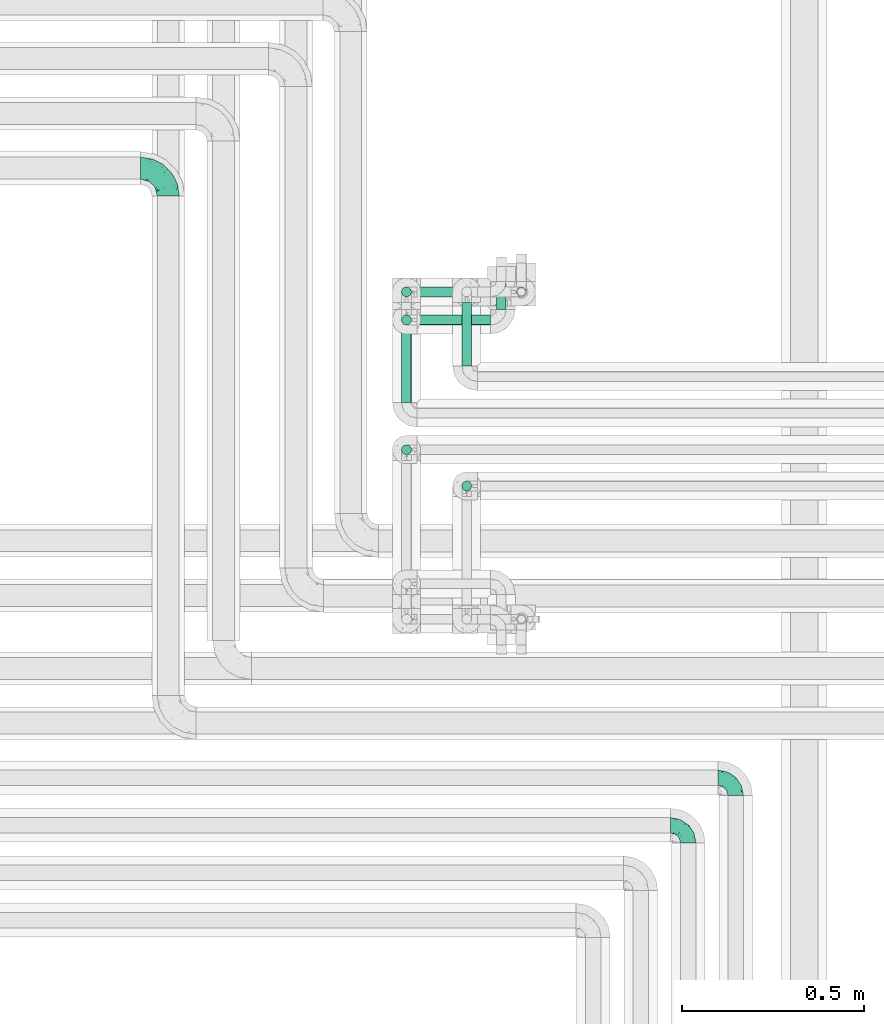
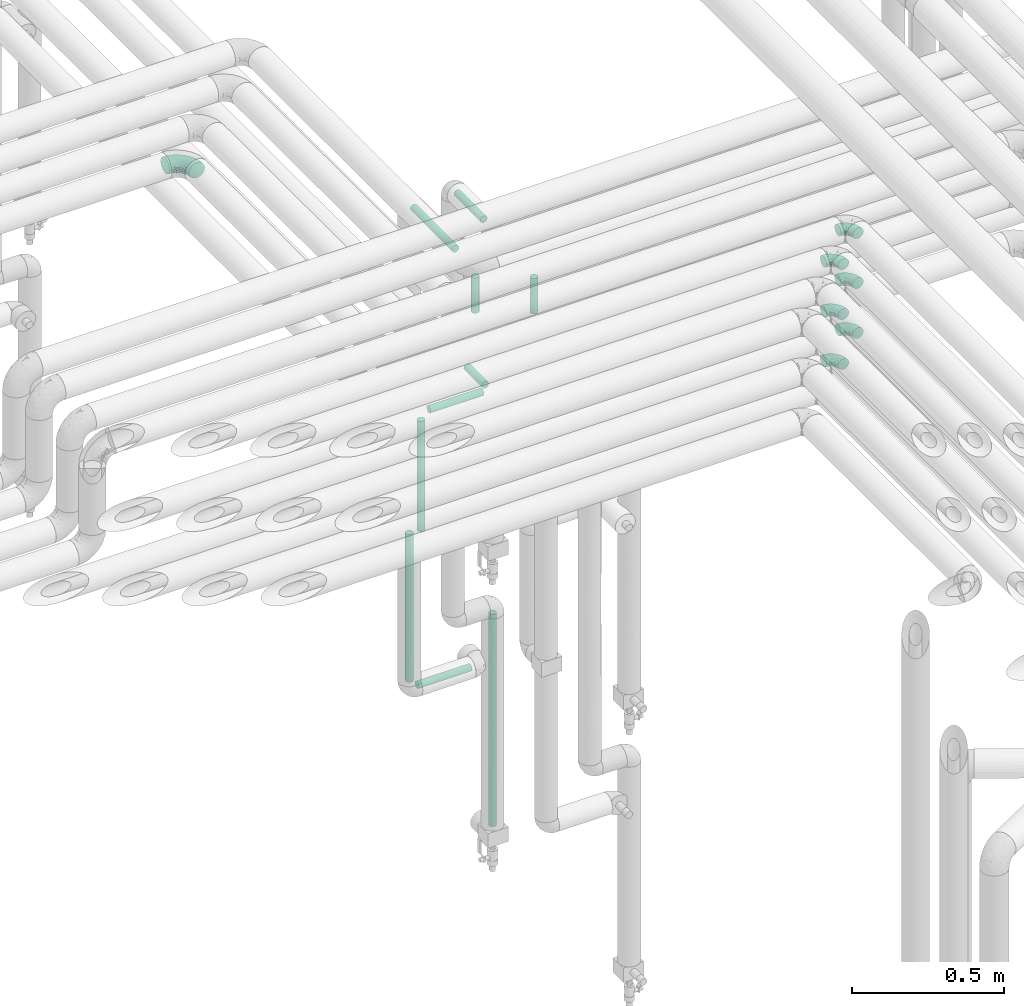
# One storey, part 636 of 827: 10 flow segments, 7 flow fittings.
"""IFC2X3 building model written with IfcOpenShell, lengths in millimetres."""

from ifc_helpers import new_model, entity, si_unit, converted_unit, derived_unit, direction, frame, origin, origin_2d_with_axis, place, context, subcontext, project, spatial, circle, extrude, faceted_brep, source, transform, mapped, material, type_object, type_shapes, element, save


model = new_model("IFC2X3")

# Units and contexts
model_context = context("Model", 3, precision=0.01, world=origin(), true_north=direction((6.12303176911189e-17, 1.0)))
body_context = subcontext(model_context, "Body", "Model", "MODEL_VIEW")
ifc_project = project(units=[si_unit("LENGTHUNIT", "METRE", prefix="MILLI"), si_unit("AREAUNIT", "SQUARE_METRE"), si_unit("VOLUMEUNIT", "CUBIC_METRE"), converted_unit("PLANEANGLEUNIT", "DEGREE", entity("IfcRatioMeasure", 0.0174532925199433), si_unit("PLANEANGLEUNIT", "RADIAN"), dimensions=[0, 0, 0, 0, 0, 0, 0]), si_unit("MASSUNIT", "GRAM", prefix="KILO"), derived_unit("MASSDENSITYUNIT", [(si_unit("MASSUNIT", "GRAM", prefix="KILO"), 1), (si_unit("LENGTHUNIT", "METRE"), -3)]), derived_unit("MOMENTOFINERTIAUNIT", [(si_unit("LENGTHUNIT", "METRE"), 4)]), si_unit("TIMEUNIT", "SECOND"), si_unit("FREQUENCYUNIT", "HERTZ"), si_unit("THERMODYNAMICTEMPERATUREUNIT", "DEGREE_CELSIUS"), derived_unit("THERMALTRANSMITTANCEUNIT", [(si_unit("MASSUNIT", "GRAM", prefix="KILO"), 1), (si_unit("THERMODYNAMICTEMPERATUREUNIT", "KELVIN"), -1), (si_unit("TIMEUNIT", "SECOND"), -3)]), derived_unit("VOLUMETRICFLOWRATEUNIT", [(si_unit("LENGTHUNIT", "METRE"), 3), (si_unit("TIMEUNIT", "SECOND"), -1)]), derived_unit("MASSFLOWRATEUNIT", [(si_unit("MASSUNIT", "GRAM", prefix="KILO"), 1), (si_unit("TIMEUNIT", "SECOND"), -1)]), derived_unit("ROTATIONALFREQUENCYUNIT", [(si_unit("TIMEUNIT", "SECOND"), -1)]), si_unit("ELECTRICCURRENTUNIT", "AMPERE"), si_unit("ELECTRICVOLTAGEUNIT", "VOLT"), si_unit("POWERUNIT", "WATT"), si_unit("FORCEUNIT", "NEWTON", prefix="KILO"), si_unit("ILLUMINANCEUNIT", "LUX"), si_unit("LUMINOUSFLUXUNIT", "LUMEN"), si_unit("LUMINOUSINTENSITYUNIT", "CANDELA"), derived_unit("USERDEFINED", [(si_unit("MASSUNIT", "GRAM", prefix="KILO"), -1), (si_unit("LENGTHUNIT", "METRE"), -2), (si_unit("TIMEUNIT", "SECOND"), 3), (si_unit("LUMINOUSFLUXUNIT", "LUMEN"), 1)]), derived_unit("LINEARVELOCITYUNIT", [(si_unit("LENGTHUNIT", "METRE"), 1), (si_unit("TIMEUNIT", "SECOND"), -1)]), si_unit("PRESSUREUNIT", "PASCAL"), derived_unit("USERDEFINED", [(si_unit("LENGTHUNIT", "METRE"), -2), (si_unit("MASSUNIT", "GRAM", prefix="KILO"), 1), (si_unit("TIMEUNIT", "SECOND"), -2)]), derived_unit("LINEARFORCEUNIT", [(si_unit("MASSUNIT", "GRAM", prefix="KILO"), 1), (si_unit("LENGTHUNIT", "METRE"), 1), (si_unit("TIMEUNIT", "SECOND"), -2), (si_unit("LENGTHUNIT", "METRE"), -1)]), derived_unit("PLANARFORCEUNIT", [(si_unit("MASSUNIT", "GRAM", prefix="KILO"), 1), (si_unit("LENGTHUNIT", "METRE"), 1), (si_unit("TIMEUNIT", "SECOND"), -2), (si_unit("LENGTHUNIT", "METRE"), -2)])], contexts=[model_context])

# Site, building, storey
site_placement = place(None, origin())
site = spatial("IfcSite", under=ifc_project, at=site_placement, CompositionType="ELEMENT")
building_placement = place(site_placement, origin())
building = spatial("IfcBuilding", under=site, at=building_placement, CompositionType="ELEMENT")
storey_placement = place(building_placement, frame((0.0, 0.0, 28200.0)))
storey = spatial("IfcBuildingStorey", under=building, at=storey_placement, Name="08", CompositionType="ELEMENT", Elevation=28200.0)

# Flow segments
pipe_segment_type = type_object("IfcPipeSegmentType", PredefinedType="NOTDEFINED")
flow_segment_1_placement = place(storey_placement, frame((34812.85, 15519.1, 2985.0)))
element("IfcFlowSegment", 1, at=flow_segment_1_placement, inside=storey, type_object=pipe_segment_type, context=body_context, shape_type="SweptSolid", body=[
    extrude(circle(Radius=13.4, at=origin_2d_with_axis()), frame((15.0, 0.0, 15.0), z_axis=(0.0, 1.0, 0.0), x_axis=(1.0, 0.0, 0.0)), (0.0, 0.0, 1.0), 273.847303750792),
])
flow_segment_2_placement = place(storey_placement, frame((34977.89, 15619.14, 2985.0)))
element("IfcFlowSegment", 2, at=flow_segment_2_placement, inside=storey, type_object=pipe_segment_type, context=body_context, shape_type="SweptSolid", body=[
    extrude(circle(Radius=13.4, at=origin_2d_with_axis()), frame((15.0, 0.0, 15.0), z_axis=(0.0, 1.0, 0.0), x_axis=(1.0, 0.0, 0.0)), (0.0, 0.0, 1.0), 173.806350271803),
])
flow_segment_3_placement = place(storey_placement, frame((35127.89, 15807.05, 401.0)))
element("IfcFlowSegment", 3, at=flow_segment_3_placement, inside=storey, type_object=pipe_segment_type, context=body_context, shape_type="SweptSolid", body=[
    extrude(circle(Radius=13.4, at=origin_2d_with_axis()), frame((15.0, 15.0, 0.0)), (0.0, 0.0, 1.0), 849.899999999534),
])
flow_segment_4_placement = place(storey_placement, frame((34812.85, 15807.05, 1089.1)))
element("IfcFlowSegment", 4, at=flow_segment_4_placement, inside=storey, type_object=pipe_segment_type, context=body_context, shape_type="SweptSolid", body=[
    extrude(circle(Radius=13.4, at=origin_2d_with_axis()), frame((15.0, 15.0, 0.0)), (0.0, 0.0, 1.0), 591.900000000008),
])
flow_segment_5_placement = place(storey_placement, frame((34856.95, 15807.05, 1045.0)))
element("IfcFlowSegment", 5, at=flow_segment_5_placement, inside=storey, type_object=pipe_segment_type, context=body_context, shape_type="SweptSolid", body=[
    extrude(circle(Radius=13.4, at=origin_2d_with_axis()), frame((0.0, 15.0, 15.0), z_axis=(1.0, 0.0, 0.0), x_axis=(0.0, -1.0, 0.0)), (0.0, 0.0, 1.0), 201.799999999997),
])
flow_segment_6_placement = place(storey_placement, frame((34856.95, 15730.06, 2195.0)))
element("IfcFlowSegment", 6, at=flow_segment_6_placement, inside=storey, type_object=pipe_segment_type, context=body_context, shape_type="SweptSolid", body=[
    extrude(circle(Radius=13.4, at=origin_2d_with_axis()), frame((0.0, 15.0, 15.0), z_axis=(1.0, 0.0, 0.0), x_axis=(0.0, 1.0, 0.0)), (0.0, 0.0, 1.0), 201.799999999997),
])
flow_segment_7_placement = place(storey_placement, frame((35072.85, 15774.15, 2195.0)))
element("IfcFlowSegment", 7, at=flow_segment_7_placement, inside=storey, type_object=pipe_segment_type, context=body_context, shape_type="SweptSolid", body=[
    extrude(circle(Radius=13.4, at=origin_2d_with_axis()), frame((15.0, 0.0, 15.0), z_axis=(0.0, 1.0, 0.0), x_axis=(-1.0, 0.0, 0.0)), (0.0, 0.0, 1.0), 117.895089895177),
])
flow_segment_8_placement = place(storey_placement, frame((34812.85, 15730.06, 1739.1)))
element("IfcFlowSegment", 8, at=flow_segment_8_placement, inside=storey, type_object=pipe_segment_type, context=body_context, shape_type="SweptSolid", body=[
    extrude(circle(Radius=13.4, at=origin_2d_with_axis()), frame((15.0, 15.0, 0.0)), (0.0, 0.0, 1.0), 441.800000000021),
])
flow_segment_9_placement = place(storey_placement, frame((34977.89, 15275.0, 2829.1)))
element("IfcFlowSegment", 9, at=flow_segment_9_placement, inside=storey, type_object=pipe_segment_type, context=body_context, shape_type="SweptSolid", body=[
    extrude(circle(Radius=13.4, at=origin_2d_with_axis()), frame((15.0, 15.0, 0.0), z_axis=(0.0, 0.0, 1.0), x_axis=(-1.0, 0.0, 0.0)), (0.0, 0.0, 1.0), 141.800000000046),
])
flow_segment_10_placement = place(storey_placement, frame((34812.85, 15374.6, 2829.1)))
element("IfcFlowSegment", 10, at=flow_segment_10_placement, inside=storey, type_object=pipe_segment_type, context=body_context, shape_type="SweptSolid", body=[
    extrude(circle(Radius=13.4, at=origin_2d_with_axis()), frame((15.0, 15.0, 0.0), z_axis=(0.0, 0.0, 1.0), x_axis=(-1.0, 0.0, 0.0)), (0.0, 0.0, 1.0), 141.800000000024),
])

# Flow fittings
ifc_material = material()
pipe_fitting_type_1 = type_object("IfcPipeFittingType", Name="ADSK_1", PredefinedType="NOTDEFINED", material=ifc_material)
shared_shape_1 = source(origin(), body_context, "Body", "Brep", [
    faceted_brep([(-48.0, 10.6, -18.36), (-48.0, 5.49, -20.48), (-48.0, 0.0, -21.2), (-48.0, -5.49, -20.48), (-48.0, -10.6, -18.36), (-48.0, -14.99, -14.99), (-48.0, -18.36, -10.6), (-48.0, -20.48, -5.49), (-48.0, -21.2, 0.0), (-48.0, -20.48, 5.49), (-48.0, -18.36, 10.6), (-48.0, -14.99, 14.99), (-48.0, -10.6, 18.36), (-48.0, -5.49, 20.48), (-48.0, 0.0, 21.2), (-48.0, 5.49, 20.48), (-48.0, 10.6, 18.36), (-48.0, 14.99, 14.99), (-48.0, 18.36, 10.6), (-48.0, 20.48, 5.49), (-48.0, 21.2, 0.0), (-48.0, 20.48, -5.49), (-48.0, 18.36, -10.6), (-48.0, 14.99, -14.99), (0.0, 48.0, -21.2), (-5.49, 48.0, -20.48), (-10.6, 48.0, -18.36), (-14.99, 48.0, -14.99), (-18.36, 48.0, -10.6), (-20.48, 48.0, -5.49), (-21.2, 48.0, 0.0), (-20.48, 48.0, 5.49), (-18.36, 48.0, 10.6), (-14.99, 48.0, 14.99), (-10.6, 48.0, 18.36), (-5.49, 48.0, 20.48), (0.0, 48.0, 21.2), (5.49, 48.0, 20.48), (10.6, 48.0, 18.36), (14.99, 48.0, 14.99), (18.36, 48.0, 10.6), (20.48, 48.0, 5.49), (21.2, 48.0, 0.0), (20.48, 48.0, -5.49), (18.36, 48.0, -10.6), (14.99, 48.0, -14.99), (10.6, 48.0, -18.36), (5.49, 48.0, -20.48), (-35.25, -16.22, 12.01), (-34.76, -18.57, 0.0), (-20.87, -12.37, 10.9), (-31.49, -11.78, 15.9), (-37.0, -2.58, 20.86), (-33.89, 3.62, 21.15), (-31.81, -18.14, 6.76), (-5.78, 5.78, 17.67), (-19.42, -4.1, 17.86), (-9.6, -3.39, 13.73), (-35.44, -7.73, 19.13), (11.78, 31.49, 15.9), (-5.93, -5.46, 6.95), (-18.45, -13.78, 5.46), (-10.29, -8.43, 0.0), (-24.6, 0.55, 20.62), (-37.28, 17.94, 13.81), (-33.38, 22.85, 9.59), (-41.46, 20.06, 8.75), (-29.51, 20.45, 15.16), (-15.04, 10.79, 21.13), (-7.08, 16.98, 20.93), (-8.39, 23.51, 21.15), (-40.86, 13.03, 17.26), (-8.05, 41.26, 19.83), (-3.21, 35.97, 21.14), (8.53, 19.66, 14.74), (4.1, 19.42, 17.86), (-37.72, 22.66, 4.78), (-37.07, 8.58, 19.98), (-13.0, 5.43, 19.97), (-3.78, 13.93, 19.7), (3.02, 8.69, 13.43), (-2.27, -0.05, 10.65), (6.22, 6.99, 7.09), (-22.25, 34.6, 9.45), (18.14, 31.81, 6.76), (16.22, 35.25, 12.01), (12.37, 20.87, 10.9), (7.73, 35.44, 19.13), (-21.52, -15.93, 0.0), (2.58, 37.0, 20.86), (18.57, 34.76, 0.0), (13.78, 18.45, 5.46), (15.93, 21.52, 0.0), (-20.03, -8.54, 14.9), (-28.6, 28.6, 5.16), (-24.79, 34.6, 0.0), (-34.6, 24.79, 0.0), (-22.81, 37.41, 4.68), (-23.36, 26.33, 14.79), (-13.68, 37.05, 17.49), (-17.72, 38.12, 13.73), (-26.25, 27.3, 11.24), (-9.71, 32.34, 20.14), (-17.26, 25.6, 18.71), (-26.33, 9.99, 20.77), (-24.06, 6.05, 21.2), (-25.02, 15.46, 19.56), (-24.3, 20.72, 17.57), (-31.95, 15.23, 17.8), (-13.53, 24.7, 20.21), (-17.6, 17.6, 20.6), (-0.55, 24.6, 20.62), (-11.41, -7.48, 10.43), (0.93, -0.93, 0.0), (8.43, 10.29, 0.0), (-11.41, -7.48, -10.43), (-20.1, -8.84, -14.66), (-9.6, -3.39, -13.73), (7.73, 35.44, -19.13), (4.1, 19.42, -17.86), (-0.55, 24.6, -20.62), (-38.12, 17.72, -13.73), (-37.05, 13.68, -17.49), (-32.34, 9.71, -20.14), (-41.26, 8.05, -19.83), (-37.41, 22.81, -4.68), (-23.51, 8.39, -21.15), (-35.97, 3.21, -21.14), (-28.6, 28.6, -5.16), (-31.81, -18.14, -6.76), (-18.45, -13.78, -5.46), (-25.6, 17.26, -18.71), (-19.42, -4.1, -17.86), (-17.94, 37.28, -13.81), (-22.85, 33.38, -9.59), (-20.06, 41.46, -8.75), (-31.49, -11.78, -15.9), (-35.25, -16.22, -12.01), (8.53, 19.66, -14.74), (11.78, 31.49, -15.9), (-9.99, 26.33, -20.77), (-6.05, 24.06, -21.2), (-10.79, 15.04, -21.13), (-37.0, -2.58, -20.86), (-16.98, 7.08, -20.93), (-5.43, 13.0, -19.97), (-13.93, 3.78, -19.7), (-20.87, -12.37, -10.9), (-26.33, 23.36, -14.79), (-22.66, 37.72, -4.78), (13.78, 18.45, -5.46), (18.14, 31.81, -6.76), (-15.46, 25.02, -19.56), (-20.72, 24.3, -17.57), (16.22, 35.25, -12.01), (-13.03, 40.86, -17.26), (-8.58, 37.07, -19.98), (2.58, 37.0, -20.86), (-3.62, 33.89, -21.15), (-34.6, 22.25, -9.45), (6.22, 6.99, -7.09), (-20.45, 29.51, -15.16), (-35.44, -7.73, -19.13), (12.37, 20.87, -10.9), (-27.3, 26.25, -11.24), (-15.23, 31.95, -17.8), (-24.7, 13.53, -20.21), (-24.6, 0.55, -20.62), (-5.78, 5.78, -17.67), (-17.6, 17.6, -20.6), (3.02, 8.69, -13.43), (-5.93, -5.46, -6.95), (-2.27, -0.05, -10.65)], [[[0, 1, 2, 3, 4, 5, 6, 7, 8, 9, 10, 11, 12, 13, 14, 15, 16, 17, 18, 19, 20, 21, 22, 23]], [[24, 25, 26, 27, 28, 29, 30, 31, 32, 33, 34, 35, 36, 37, 38, 39, 40, 41, 42, 43, 44, 45, 46, 47]], [[10, 48, 11]], [[9, 8, 49]], [[48, 50, 51]], [[14, 52, 53]], [[10, 54, 48]], [[9, 54, 10]], [[55, 56, 57]], [[51, 12, 11]], [[51, 58, 12]], [[59, 39, 38]], [[60, 61, 62]], [[58, 56, 63]], [[64, 65, 66]], [[67, 65, 64]], [[68, 69, 70]], [[16, 71, 17]], [[13, 52, 14]], [[35, 72, 73]], [[14, 53, 15]], [[17, 64, 18]], [[74, 59, 75]], [[20, 19, 76]], [[66, 19, 18]], [[77, 15, 53]], [[15, 77, 16]], [[69, 78, 79]], [[80, 81, 82]], [[32, 31, 83]], [[84, 85, 86]], [[59, 87, 75]], [[61, 54, 88]], [[36, 89, 37]], [[84, 41, 40]], [[36, 35, 73]], [[90, 41, 84]], [[40, 39, 85]], [[12, 58, 13]], [[85, 84, 40]], [[91, 84, 86]], [[84, 92, 90]], [[87, 38, 37]], [[93, 56, 51]], [[65, 94, 76]], [[94, 95, 96]], [[84, 91, 92]], [[95, 97, 30]], [[98, 99, 100]], [[76, 94, 96]], [[101, 98, 83]], [[100, 99, 33]], [[102, 70, 73]], [[103, 102, 99]], [[94, 97, 95]], [[72, 99, 102]], [[72, 35, 34]], [[34, 33, 99]], [[9, 49, 54]], [[87, 59, 38]], [[104, 105, 68]], [[106, 103, 107]], [[106, 77, 104]], [[71, 64, 17]], [[108, 107, 67]], [[33, 32, 100]], [[109, 103, 110]], [[102, 109, 70]], [[89, 73, 111]], [[50, 48, 54]], [[51, 11, 48]], [[56, 58, 51]], [[88, 54, 49]], [[52, 58, 63]], [[50, 112, 93]], [[56, 55, 78]], [[39, 59, 85]], [[86, 85, 59]], [[89, 87, 37]], [[42, 41, 90]], [[111, 79, 75]], [[111, 75, 87]], [[75, 55, 80]], [[104, 77, 53]], [[71, 77, 108]], [[32, 83, 100]], [[98, 100, 83]], [[99, 98, 103]], [[106, 107, 108]], [[68, 70, 110]], [[111, 73, 70]], [[68, 110, 104]], [[68, 63, 78]], [[57, 93, 112]], [[80, 55, 57]], [[61, 50, 54]], [[80, 82, 86]], [[81, 57, 112]], [[74, 86, 59]], [[60, 113, 82]], [[82, 114, 91]], [[101, 94, 65]], [[97, 94, 83]], [[73, 89, 36]], [[87, 89, 111]], [[58, 52, 13]], [[53, 52, 63]], [[104, 53, 105]], [[106, 104, 110]], [[20, 76, 96]], [[76, 19, 66]], [[103, 106, 110]], [[77, 106, 108]], [[103, 98, 107]], [[67, 107, 98]], [[67, 98, 101]], [[108, 67, 64]], [[53, 63, 105]], [[63, 68, 105]], [[83, 31, 97]], [[30, 97, 31]], [[62, 113, 60]], [[112, 61, 60]], [[61, 88, 62]], [[86, 82, 91]], [[56, 78, 63]], [[114, 82, 113]], [[114, 92, 91]], [[79, 78, 55]], [[75, 79, 55]], [[69, 79, 111]], [[70, 69, 111]], [[78, 69, 68]], [[77, 71, 16]], [[64, 71, 108]], [[64, 66, 18]], [[76, 66, 65]], [[99, 72, 34]], [[73, 72, 102]], [[94, 101, 83]], [[67, 101, 65]], [[75, 80, 74]], [[80, 86, 74]], [[70, 109, 110]], [[102, 103, 109]], [[50, 93, 51]], [[57, 56, 93]], [[61, 112, 50]], [[81, 112, 60]], [[82, 81, 60]], [[80, 57, 81]], [[115, 116, 117]], [[118, 119, 120]], [[121, 122, 23]], [[123, 124, 122]], [[96, 125, 20]], [[123, 126, 127]], [[128, 96, 95]], [[129, 130, 88]], [[123, 122, 131]], [[116, 132, 117]], [[133, 134, 135]], [[0, 124, 1]], [[5, 136, 137]], [[138, 119, 139]], [[129, 88, 49]], [[140, 141, 142]], [[6, 5, 137]], [[46, 118, 47]], [[143, 3, 2]], [[144, 145, 146]], [[6, 129, 7]], [[129, 137, 147]], [[127, 2, 1]], [[148, 122, 121]], [[128, 125, 96]], [[134, 128, 149]], [[95, 149, 128]], [[150, 151, 92]], [[30, 29, 149]], [[152, 131, 153]], [[27, 133, 28]], [[154, 45, 44]], [[136, 5, 4]], [[27, 26, 155]], [[156, 26, 25]], [[24, 157, 158]], [[24, 47, 157]], [[22, 21, 159]], [[160, 150, 114]], [[134, 133, 161]], [[142, 144, 126]], [[46, 139, 118]], [[162, 136, 4]], [[156, 25, 158]], [[1, 124, 127]], [[115, 147, 116]], [[45, 154, 139]], [[139, 46, 45]], [[154, 163, 139]], [[162, 4, 3]], [[42, 90, 43]], [[130, 129, 147]], [[49, 7, 129]], [[43, 151, 44]], [[0, 23, 122]], [[24, 158, 25]], [[136, 162, 132]], [[135, 29, 28]], [[43, 90, 151]], [[164, 148, 159]], [[152, 156, 140]], [[155, 133, 27]], [[165, 153, 161]], [[23, 22, 121]], [[123, 131, 166]], [[123, 166, 126]], [[143, 127, 167]], [[147, 137, 136]], [[8, 7, 49]], [[129, 6, 137]], [[143, 162, 3]], [[167, 146, 132]], [[167, 132, 162]], [[132, 168, 117]], [[44, 151, 154]], [[92, 151, 90]], [[163, 154, 151]], [[119, 118, 139]], [[157, 118, 120]], [[138, 139, 163]], [[119, 168, 145]], [[140, 156, 158]], [[155, 156, 165]], [[22, 159, 121]], [[148, 121, 159]], [[122, 148, 131]], [[152, 153, 165]], [[142, 126, 169]], [[167, 127, 126]], [[142, 169, 140]], [[142, 120, 145]], [[168, 170, 117]], [[160, 171, 172]], [[115, 172, 171]], [[171, 62, 130]], [[119, 170, 168]], [[170, 163, 160]], [[150, 163, 151]], [[113, 171, 160]], [[164, 128, 134]], [[125, 128, 159]], [[127, 143, 2]], [[162, 143, 167]], [[118, 157, 47]], [[158, 157, 120]], [[140, 158, 141]], [[152, 140, 169]], [[30, 149, 95]], [[149, 29, 135]], [[131, 152, 169]], [[156, 152, 165]], [[131, 148, 153]], [[161, 153, 148]], [[161, 148, 164]], [[165, 161, 133]], [[158, 120, 141]], [[120, 142, 141]], [[159, 21, 125]], [[20, 125, 21]], [[115, 130, 147]], [[114, 113, 160]], [[62, 171, 113]], [[62, 88, 130]], [[160, 163, 150]], [[150, 92, 114]], [[119, 145, 120]], [[146, 145, 168]], [[132, 146, 168]], [[144, 146, 167]], [[126, 144, 167]], [[145, 144, 142]], [[156, 155, 26]], [[133, 155, 165]], [[133, 135, 28]], [[149, 135, 134]], [[122, 124, 0]], [[127, 124, 123]], [[128, 164, 159]], [[161, 164, 134]], [[163, 170, 138]], [[170, 119, 138]], [[131, 169, 166]], [[126, 166, 169]], [[147, 136, 116]], [[132, 116, 136]], [[172, 115, 117]], [[130, 115, 171]], [[117, 170, 172]], [[160, 172, 170]]]),
])
type_shapes(pipe_fitting_type_1, [shared_shape_1])
for number, where, z_axis, x_axis, name in (
    (11, (35730.03, 14490.0, 3000.0), (0.0, 0.0, 1.0), (0.0, 1.0, 0.0), "ADSK_1"),
    (12, (35600.09, 14360.0, 3000.0), (0.0, 0.0, 1.0), (0.0, 1.0, 0.0), "ADSK_1"),
    (13, (35600.09, 14360.0, 3200.0), (0.0, 0.0, 1.0), (0.0, 1.0, 0.0), "ADSK_1"),
    (14, (35730.03, 14490.0, 3200.0), (0.0, 0.0, 1.0), (0.0, 1.0, 0.0), "ADSK_1"),
    (15, (35600.09, 14360.0, 3400.0), (0.0, 0.0, 1.0), (0.0, 1.0, 0.0), "ADSK_1"),
    (16, (35730.03, 14490.0, 3400.0), (0.0, 0.0, 1.0), (0.0, 1.0, 0.0), "ADSK_1"),
):
    element("IfcFlowFitting", number, at=place(storey_placement, frame(where, z_axis=z_axis, x_axis=x_axis)), inside=storey, type_object=pipe_fitting_type_1, material=ifc_material, Name=name, ObjectType="ADSK_1", context=body_context, shape_type="MappedRepresentation", body=[
        mapped(shared_shape_1, transform((0.0, 0.0, 0.0), scale=1.0)),
    ])
pipe_fitting_type_2 = type_object("IfcPipeFittingType", Name="ADSK_1", PredefinedType="NOTDEFINED", material=ifc_material)
shared_shape_2 = source(origin(), body_context, "Body", "Brep", [
    faceted_brep([(-76.0, 15.07, -26.11), (-76.0, 7.8, -29.12), (-76.0, 0.0, -30.15), (-76.0, -7.8, -29.12), (-76.0, -15.08, -26.11), (-76.0, -21.32, -21.32), (-76.0, -26.11, -15.08), (-76.0, -29.12, -7.8), (-76.0, -30.15, 0.0), (-76.0, -29.12, 7.8), (-76.0, -26.11, 15.07), (-76.0, -21.32, 21.32), (-76.0, -15.08, 26.11), (-76.0, -7.8, 29.12), (-76.0, 0.0, 30.15), (-76.0, 7.8, 29.12), (-76.0, 15.07, 26.11), (-76.0, 21.32, 21.32), (-76.0, 26.11, 15.07), (-76.0, 29.12, 7.8), (-76.0, 30.15, 0.0), (-76.0, 29.12, -7.8), (-76.0, 26.11, -15.08), (-76.0, 21.32, -21.32), (0.0, 76.0, -30.15), (-7.8, 76.0, -29.12), (-15.07, 76.0, -26.11), (-21.32, 76.0, -21.32), (-26.11, 76.0, -15.08), (-29.12, 76.0, -7.8), (-30.15, 76.0, 0.0), (-29.12, 76.0, 7.8), (-26.11, 76.0, 15.07), (-21.32, 76.0, 21.32), (-15.07, 76.0, 26.11), (-7.8, 76.0, 29.12), (0.0, 76.0, 30.15), (7.8, 76.0, 29.12), (15.08, 76.0, 26.11), (21.32, 76.0, 21.32), (26.11, 76.0, 15.07), (29.12, 76.0, 7.8), (30.15, 76.0, 0.0), (29.12, 76.0, -7.8), (26.11, 76.0, -15.08), (21.32, 76.0, -21.32), (15.08, 76.0, -26.11), (7.8, 76.0, -29.12), (10.79, 31.43, 21.07), (4.32, 31.7, 25.72), (1.65, 15.19, 19.92), (-61.17, -27.8, 0.0), (-51.1, -25.49, 9.84), (-56.14, -10.61, 27.27), (-31.7, -4.32, 25.72), (-39.75, 1.72, 29.41), (-43.2, -24.95, 0.0), (-1.86, 1.86, 0.0), (4.49, 7.65, 5.78), (-7.82, -4.61, 5.83), (-56.21, -22.79, 17.21), (-58.98, -3.38, 29.7), (-53.96, 5.6, 30.07), (-10.86, 10.86, 25.48), (-17.2, -2.6, 20.44), (-49.15, -16.01, 22.7), (-22.18, -14.24, 7.99), (-28.4, -17.42, 0.0), (-13.61, -9.88, 0.0), (-39.0, 23.48, 27.76), (-58.76, 12.54, 28.36), (-41.61, 15.41, 29.48), (16.01, 49.15, 22.7), (-58.55, 25.93, 19.53), (-51.53, 33.5, 13.51), (-64.92, 28.76, 12.4), (-7.48, 23.14, 28.25), (-1.72, 39.75, 29.41), (-12.04, 27.88, 29.88), (-63.91, 18.81, 24.52), (-11.63, 65.16, 28.18), (-4.97, 57.02, 30.05), (9.88, 13.61, 0.0), (-62.5, 31.74, 5.02), (-45.17, 30.98, 21.2), (-21.78, 9.76, 28.58), (10.61, 56.14, 27.27), (-32.09, 54.42, 13.26), (22.79, 56.21, 17.21), (15.38, 31.17, 15.63), (25.49, 51.1, 9.84), (21.84, 36.35, 5.92), (24.95, 43.2, 0.0), (3.38, 58.98, 29.7), (-31.17, -15.38, 15.63), (-39.39, 41.78, 15.45), (-34.56, 41.13, 20.79), (-39.81, -23.25, 5.49), (27.8, 61.17, 0.0), (-31.74, 62.5, 5.02), (-53.07, 36.29, 0.0), (-42.95, 42.95, 7.29), (-36.29, 53.07, 0.0), (-19.83, 58.51, 24.79), (-25.48, 60.2, 19.41), (-14.53, 50.96, 28.57), (-13.31, 37.09, 30.07), (-26.16, 40.06, 26.4), (-32.43, -10.35, 21.9), (17.42, 28.4, 0.0), (14.24, 22.18, 7.99), (-38.67, 9.72, 30.15), (-24.66, 17.36, 30.09), (-37.08, 31.49, 24.99), (-49.27, 22.83, 25.24), (-20.8, 38.81, 28.63), (-27.58, 27.58, 29.2), (-36.07, -20.23, 10.71), (-15.19, -6.16, 14.9), (6.6, 15.4, 14.49), (-2.51, 2.51, 11.35), (-65.16, 11.63, -28.18), (-49.15, -16.01, -22.7), (-57.02, 4.97, -30.05), (-25.93, 58.55, -19.53), (-33.5, 51.53, -13.51), (-28.76, 64.92, -12.4), (-60.2, 25.48, -19.41), (-58.51, 19.83, -24.79), (4.61, 7.82, -5.83), (-7.65, -4.49, -5.78), (-2.51, 2.51, -11.35), (-62.5, 31.74, -5.02), (-50.96, 14.53, -28.57), (-37.09, 13.31, -30.07), (-42.95, 42.95, -7.29), (25.49, 51.1, -9.84), (22.79, 56.21, -17.21), (-40.06, 26.16, -26.4), (3.38, 58.98, -29.7), (-5.6, 53.96, -30.07), (-27.88, 12.04, -29.88), (-9.76, 21.78, -28.58), (-23.14, 7.48, -28.25), (-51.1, -25.49, -9.84), (15.38, 31.17, -15.63), (16.01, 49.15, -22.7), (-23.48, 39.0, -27.76), (-12.54, 58.76, -28.36), (-15.41, 41.61, -29.48), (-56.21, -22.79, -17.21), (-9.72, 38.67, -30.15), (-17.36, 24.66, -30.09), (-22.18, -14.24, -7.99), (-41.13, 34.56, -20.79), (-31.74, 62.5, -5.02), (-58.98, -3.38, -29.7), (-31.17, -15.38, -15.63), (-56.14, -10.61, -27.27), (14.24, 22.18, -7.99), (23.25, 39.81, -5.49), (-31.49, 37.08, -24.99), (-15.19, -6.16, -14.9), (1.65, 15.19, -19.92), (-18.81, 63.91, -24.52), (-32.59, -11.62, -20.84), (-31.7, -4.32, -25.72), (-17.2, -2.6, -20.44), (-39.75, 1.72, -29.41), (-54.42, 32.09, -13.26), (-30.98, 45.17, -21.2), (10.61, 56.14, -27.27), (10.23, 31.31, -21.52), (4.32, 31.7, -25.72), (-41.78, 39.39, -15.45), (-1.72, 39.75, -29.41), (-36.35, -21.84, -5.92), (-22.83, 49.27, -25.24), (-38.81, 20.8, -28.63), (-27.58, 27.58, -29.2), (-10.86, 10.86, -25.48), (20.23, 36.07, -10.71), (6.6, 15.4, -14.49)], [[[0, 1, 2, 3, 4, 5, 6, 7, 8, 9, 10, 11, 12, 13, 14, 15, 16, 17, 18, 19, 20, 21, 22, 23]], [[24, 25, 26, 27, 28, 29, 30, 31, 32, 33, 34, 35, 36, 37, 38, 39, 40, 41, 42, 43, 44, 45, 46, 47]], [[48, 49, 50]], [[51, 52, 9]], [[53, 54, 55]], [[9, 52, 10]], [[56, 52, 51]], [[57, 58, 59]], [[11, 10, 60]], [[14, 61, 62]], [[63, 54, 64]], [[65, 12, 11]], [[65, 53, 12]], [[66, 67, 68]], [[69, 70, 71]], [[72, 39, 38]], [[73, 74, 75]], [[15, 70, 16]], [[76, 77, 78]], [[16, 79, 17]], [[13, 61, 14]], [[35, 80, 81]], [[14, 62, 15]], [[17, 73, 18]], [[57, 82, 58]], [[20, 19, 83]], [[75, 19, 18]], [[70, 15, 62]], [[73, 84, 74]], [[78, 85, 76]], [[38, 86, 72]], [[32, 31, 87]], [[88, 89, 90]], [[91, 92, 90]], [[72, 86, 49]], [[36, 93, 37]], [[75, 83, 19]], [[36, 35, 81]], [[60, 94, 65]], [[40, 90, 41]], [[95, 96, 87]], [[88, 90, 40]], [[66, 97, 67]], [[90, 98, 41]], [[40, 39, 88]], [[99, 31, 30]], [[20, 83, 100]], [[101, 102, 100]], [[52, 60, 10]], [[102, 99, 30]], [[96, 103, 104]], [[83, 101, 100]], [[12, 53, 13]], [[104, 103, 33]], [[105, 106, 81]], [[107, 105, 103]], [[64, 54, 108]], [[80, 103, 105]], [[80, 35, 34]], [[34, 33, 103]], [[86, 38, 37]], [[109, 110, 82]], [[71, 111, 112]], [[69, 107, 113]], [[79, 73, 17]], [[114, 113, 84]], [[33, 32, 104]], [[115, 107, 116]], [[105, 115, 106]], [[93, 81, 77]], [[54, 53, 65]], [[61, 53, 55]], [[108, 94, 64]], [[54, 63, 85]], [[93, 86, 37]], [[77, 76, 49]], [[77, 49, 86]], [[49, 63, 50]], [[60, 52, 117]], [[65, 11, 60]], [[39, 72, 88]], [[89, 88, 72]], [[71, 70, 62]], [[79, 70, 114]], [[103, 96, 107]], [[69, 113, 114]], [[112, 106, 116]], [[77, 81, 106]], [[112, 116, 71]], [[112, 55, 85]], [[64, 50, 63]], [[57, 59, 68]], [[32, 87, 104]], [[96, 104, 87]], [[94, 118, 64]], [[50, 119, 89]], [[50, 64, 118]], [[50, 89, 48]], [[81, 93, 36]], [[86, 93, 77]], [[53, 61, 13]], [[62, 61, 55]], [[71, 62, 111]], [[69, 71, 116]], [[95, 101, 74]], [[99, 101, 87]], [[118, 66, 59]], [[117, 97, 66]], [[117, 66, 94]], [[91, 89, 110]], [[91, 110, 109]], [[110, 89, 119]], [[9, 8, 51]], [[98, 90, 92]], [[98, 42, 41]], [[101, 83, 74]], [[101, 99, 102]], [[87, 31, 99]], [[62, 55, 111]], [[55, 112, 111]], [[107, 69, 116]], [[70, 69, 114]], [[107, 96, 113]], [[84, 113, 96]], [[84, 96, 95]], [[114, 84, 73]], [[70, 79, 16]], [[73, 79, 114]], [[54, 85, 55]], [[76, 85, 63]], [[49, 76, 63]], [[77, 106, 78]], [[106, 112, 78]], [[85, 78, 112]], [[73, 75, 18]], [[83, 75, 74]], [[103, 80, 34]], [[81, 80, 105]], [[101, 95, 87]], [[84, 95, 74]], [[106, 115, 116]], [[105, 107, 115]], [[120, 59, 58]], [[82, 110, 58]], [[119, 58, 110]], [[118, 59, 120]], [[66, 68, 59]], [[54, 65, 108]], [[94, 108, 65]], [[66, 118, 94]], [[50, 118, 120]], [[50, 120, 119]], [[119, 120, 58]], [[89, 72, 48]], [[49, 48, 72]], [[60, 117, 94]], [[117, 52, 97]], [[52, 56, 97]], [[67, 97, 56]], [[92, 91, 109]], [[89, 91, 90]], [[121, 1, 0]], [[122, 5, 4]], [[2, 1, 123]], [[124, 125, 126]], [[127, 128, 23]], [[129, 130, 131]], [[100, 132, 20]], [[133, 134, 123]], [[135, 100, 102]], [[136, 137, 44]], [[133, 128, 138]], [[24, 139, 140]], [[141, 142, 143]], [[121, 128, 133]], [[6, 144, 7]], [[137, 145, 146]], [[144, 51, 7]], [[147, 148, 149]], [[144, 6, 150]], [[149, 151, 152]], [[153, 68, 67]], [[154, 128, 127]], [[30, 155, 102]], [[43, 42, 98]], [[156, 3, 2]], [[157, 144, 150]], [[158, 4, 3]], [[24, 140, 25]], [[155, 135, 102]], [[159, 160, 109]], [[30, 29, 155]], [[147, 138, 161]], [[27, 124, 28]], [[57, 129, 82]], [[162, 163, 131]], [[27, 26, 164]], [[148, 26, 25]], [[165, 166, 167]], [[24, 47, 139]], [[143, 168, 141]], [[22, 21, 169]], [[125, 124, 170]], [[148, 25, 140]], [[46, 146, 171]], [[158, 122, 4]], [[0, 23, 128]], [[1, 121, 123]], [[109, 82, 159]], [[45, 44, 137]], [[146, 46, 45]], [[136, 43, 98]], [[132, 21, 20]], [[136, 98, 92]], [[172, 173, 146]], [[46, 171, 47]], [[43, 136, 44]], [[174, 154, 169]], [[171, 173, 175]], [[6, 5, 150]], [[126, 29, 28]], [[176, 56, 144]], [[122, 158, 166]], [[164, 124, 27]], [[177, 161, 170]], [[23, 22, 127]], [[178, 138, 179]], [[133, 178, 134]], [[156, 123, 168]], [[156, 158, 3]], [[168, 143, 166]], [[168, 166, 158]], [[166, 180, 167]], [[173, 171, 146]], [[139, 171, 175]], [[172, 145, 163]], [[173, 180, 142]], [[5, 122, 150]], [[157, 150, 122]], [[137, 136, 181]], [[146, 45, 137]], [[149, 148, 140]], [[164, 148, 177]], [[128, 154, 138]], [[147, 161, 177]], [[152, 134, 179]], [[168, 123, 134]], [[152, 179, 149]], [[152, 175, 142]], [[57, 130, 129]], [[157, 165, 167]], [[22, 169, 127]], [[154, 127, 169]], [[163, 167, 180]], [[162, 157, 167]], [[173, 163, 180]], [[182, 163, 145]], [[123, 156, 2]], [[158, 156, 168]], [[171, 139, 47]], [[140, 139, 175]], [[149, 140, 151]], [[147, 149, 179]], [[174, 135, 125]], [[132, 135, 169]], [[176, 157, 153]], [[176, 153, 67]], [[153, 157, 162]], [[182, 159, 129]], [[181, 160, 159]], [[181, 159, 145]], [[51, 144, 56]], [[51, 8, 7]], [[135, 132, 100]], [[169, 21, 132]], [[126, 155, 29]], [[135, 155, 125]], [[140, 175, 151]], [[175, 152, 151]], [[138, 147, 179]], [[148, 147, 177]], [[138, 154, 161]], [[170, 161, 154]], [[170, 154, 174]], [[177, 170, 124]], [[148, 164, 26]], [[124, 164, 177]], [[173, 142, 175]], [[143, 142, 180]], [[166, 143, 180]], [[168, 134, 141]], [[134, 152, 141]], [[142, 141, 152]], [[124, 126, 28]], [[155, 126, 125]], [[128, 121, 0]], [[123, 121, 133]], [[135, 174, 169]], [[170, 174, 125]], [[134, 178, 179]], [[133, 138, 178]], [[130, 153, 162]], [[68, 153, 130]], [[57, 68, 130]], [[182, 129, 131]], [[159, 82, 129]], [[157, 122, 165]], [[166, 165, 122]], [[163, 162, 167]], [[162, 131, 130]], [[145, 172, 146]], [[163, 173, 172]], [[159, 182, 145]], [[131, 163, 182]], [[56, 176, 67]], [[157, 176, 144]], [[137, 181, 145]], [[181, 136, 160]], [[136, 92, 160]], [[109, 160, 92]]]),
])
type_shapes(pipe_fitting_type_2, [shared_shape_2])
flow_fitting_placement = place(storey_placement, frame((34175.03, 16161.2, 3200.0), z_axis=(0.0, 0.0, 1.0), x_axis=(0.0, 1.0, 0.0)))
element("IfcFlowFitting", 17, at=flow_fitting_placement, inside=storey, type_object=pipe_fitting_type_2, material=ifc_material, Name="ADSK_1", ObjectType="ADSK_1", context=body_context, shape_type="MappedRepresentation", body=[
    mapped(shared_shape_2, transform((0.0, 0.0, 0.0), scale=1.0)),
])

save(model, "model.ifc")
